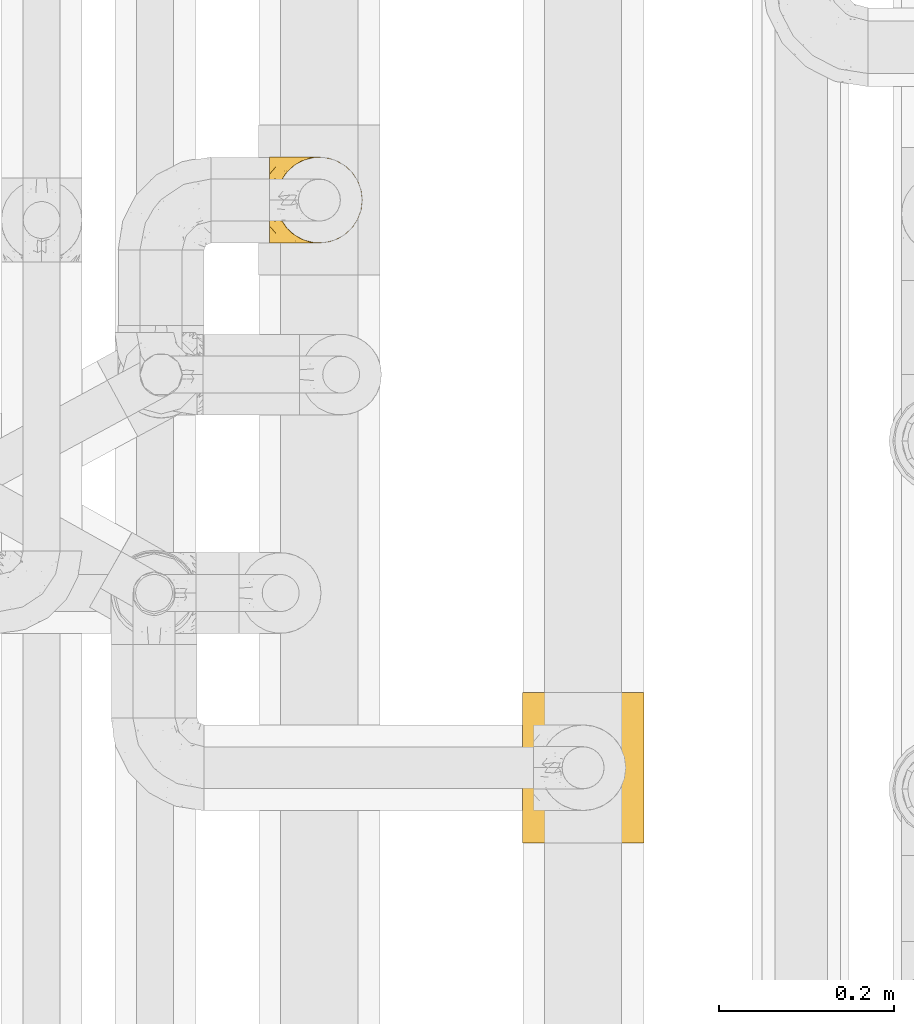
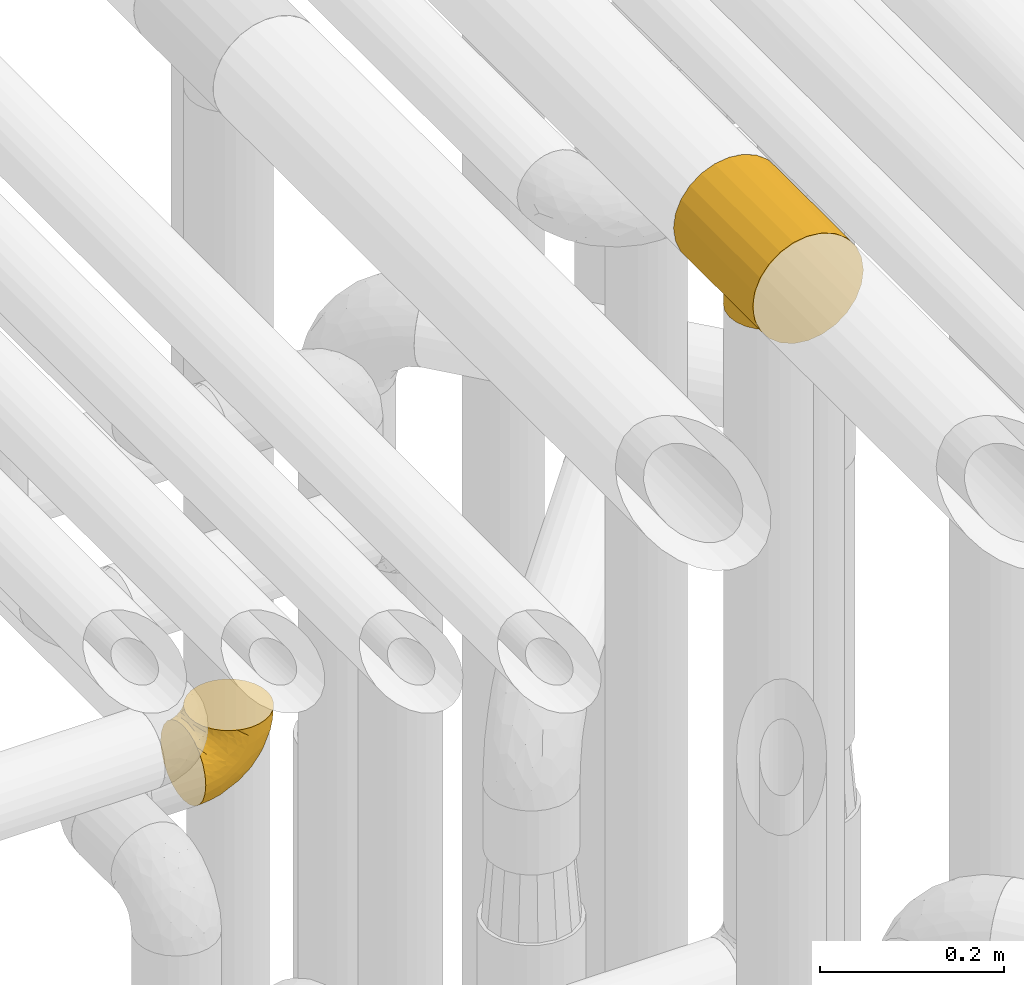
# One storey, part 210 of 827: 2 coverings.
"""IFC2X3 building model written with IfcOpenShell, lengths in millimetres."""

import ifcopenshell
import ifcopenshell.guid

model = None  # the IFC model being written
_history = None  # IfcOwnerHistory: only IFC2X3 demands one
_inside = {}  # id of a spatial element -> (the spatial element, [elements in it])
_under = {}  # id of a project, library or spatial element -> (it, [spatial elements below it])
_declared = {}  # id of a project -> (the project, [libraries it declares])
_typed = {}  # id of a type object -> (the type object, [elements of that type])
_made_of = {}  # id of a material, layer set ... -> (it, [elements and type objects made of it])


def new_model(schema):
    """Start an empty IFC model of exactly this schema.

    Asked for "IFC4X3", IfcOpenShell would pick the latest addendum, in which some entities
    have other attributes; the version numbers below select the first issue.
    IFC2X3 requires an IfcOwnerHistory on every rooted entity: one is made here for all.
    """
    global model, _history
    if schema == "IFC4X3":
        model = ifcopenshell.file(schema_version=(4, 3, 0, 0))
    else:
        model = ifcopenshell.file(schema=schema)
    _inside.clear()
    _under.clear()
    _declared.clear()
    _typed.clear()
    _made_of.clear()
    _history = None
    if model.schema == "IFC2X3":
        org = make("IfcOrganization", Name="unknown")
        user = make(
            "IfcPersonAndOrganization",
            ThePerson=make("IfcPerson", FamilyName="unknown"),
            TheOrganization=org,
        )
        app = make(
            "IfcApplication",
            ApplicationDeveloper=org,
            Version="unknown",
            ApplicationFullName="unknown",
            ApplicationIdentifier="unknown",
        )
        _history = make(
            "IfcOwnerHistory",
            OwningUser=user,
            OwningApplication=app,
            ChangeAction="ADDED",
            CreationDate=0,
        )
    return model


def make(cls, **values):
    """One entity of the class cls with the attributes given. An attribute that is None is left unset."""
    return model.create_entity(
        cls, **{name: value for name, value in values.items() if value is not None}
    )


def entity(cls, *values):
    """Any entity or typed value of the class cls, its attributes in the order of the schema. None: left unset."""
    e = model.create_entity(cls)
    for i, value in enumerate(values):
        if value is not None:
            e[i] = value
    return e


def rooted(cls, **values):
    """An entity with a GlobalId (a new one), such as an element, a storey or a relation."""
    return make(cls, GlobalId=ifcopenshell.guid.new(), OwnerHistory=_history, **values)


def si_unit(unit_type, name, prefix=None):
    """IfcSIUnit, for example si_unit("LENGTHUNIT", "METRE", prefix="MILLI")."""
    return make("IfcSIUnit", UnitType=unit_type, Prefix=prefix, Name=name)


def converted_unit(unit_type, name, factor, base, dimensions=None, offset=None):
    """IfcConversionBasedUnit, such as the inch: factor (a typed value) times the base unit."""
    return make(
        "IfcConversionBasedUnit"
        if offset is None
        else "IfcConversionBasedUnitWithOffset",
        ConversionOffset=offset,
        Dimensions=None
        if dimensions is None
        else entity("IfcDimensionalExponents", *dimensions),
        UnitType=unit_type,
        Name=name,
        ConversionFactor=make(
            "IfcMeasureWithUnit", ValueComponent=factor, UnitComponent=base
        ),
    )


def derived_unit(unit_type, elements):
    """IfcDerivedUnit: a product of units, each with its exponent."""
    return make(
        "IfcDerivedUnit",
        Elements=[
            make("IfcDerivedUnitElement", Unit=unit, Exponent=power)
            for unit, power in elements
        ],
        UnitType=unit_type,
    )


def assignment(units):
    """IfcUnitAssignment: the units of a project."""
    return None if units is None else make("IfcUnitAssignment", Units=units)


def point(xyz):
    """IfcCartesianPoint."""
    return None if xyz is None else make("IfcCartesianPoint", Coordinates=xyz)


def direction(xyz):
    """IfcDirection."""
    return None if xyz is None else make("IfcDirection", DirectionRatios=xyz)


def frame(location, z_axis=None, x_axis=None):
    """IfcAxis2Placement3D, a coordinate frame: its origin and axes. An axis left out is left unset."""
    return make(
        "IfcAxis2Placement3D",
        Location=point(location),
        Axis=direction(z_axis),
        RefDirection=direction(x_axis),
    )


def origin():
    """The frame at (0, 0, 0) with its axes left unset."""
    return frame((0.0, 0.0, 0.0))


def place(relative_to, where):
    """IfcLocalPlacement: puts the frame where relative to a parent placement (None: the world)."""
    return make(
        "IfcLocalPlacement", PlacementRelTo=relative_to, RelativePlacement=where
    )


def context(
    kind, dimensions, precision=None, world=None, true_north=None, identifier=None
):
    """IfcGeometricRepresentationContext, for example the 3D "Model" context."""
    return make(
        "IfcGeometricRepresentationContext",
        ContextIdentifier=identifier,
        ContextType=kind,
        CoordinateSpaceDimension=dimensions,
        Precision=precision,
        WorldCoordinateSystem=world,
        TrueNorth=true_north,
    )


def subcontext(parent, identifier, kind, view, scale=None):
    """IfcGeometricRepresentationSubContext, for example "Body" below "Model"."""
    return make(
        "IfcGeometricRepresentationSubContext",
        ContextIdentifier=identifier,
        ContextType=kind,
        ParentContext=parent,
        TargetScale=scale,
        TargetView=view,
    )


def project(units=None, contexts=None):
    """IfcProject with its units and contexts."""
    return rooted(
        "IfcProject",
        Name="project",
        RepresentationContexts=contexts,
        UnitsInContext=assignment(units),
    )


def spatial(cls, under=None, at=None, **own):
    """A site, building, storey or space (cls), placed at a placement, below another one or the project."""
    s = rooted(cls, ObjectPlacement=at, **own)
    if under is not None:
        _under.setdefault(under.id(), (under, []))[1].append(s)
    return s


def faces_of(points, faces, orient=None, outer=None):
    """IfcFace entities. A face is a list of loops; a loop is a list of indices into points, from 0.

    orient and outer hold one flag for each loop. By default every Orientation is true, the
    first loop of a face is its IfcFaceOuterBound and the others are IfcFaceBound.
    """
    made = []
    for i, loops in enumerate(faces):
        bounds = []
        for j, loop in enumerate(loops):
            is_outer = j == 0 if outer is None else outer[i][j]
            bounds.append(
                make(
                    "IfcFaceOuterBound" if is_outer else "IfcFaceBound",
                    Bound=make("IfcPolyLoop", Polygon=[points[k] for k in loop]),
                    Orientation=True if orient is None else orient[i][j],
                )
            )
        made.append(make("IfcFace", Bounds=bounds))
    return made


def faceted_brep(points, faces, orient=None, outer=None, voids=None):
    """IfcFacetedBrep: a solid bounded by flat faces; with voids (closed shells), ...WithVoids."""
    shared = [point(p) for p in points]
    hull = make("IfcClosedShell", CfsFaces=faces_of(shared, faces, orient, outer))
    if voids is None:
        return make("IfcFacetedBrep", Outer=hull)
    return make(
        "IfcFacetedBrepWithVoids",
        Outer=hull,
        Voids=[
            make(cls, CfsFaces=faces_of(shared, fs, o, b)) for cls, fs, o, b in voids
        ],
    )


def shape(context_of_items, identifier, shape_type, items):
    """IfcShapeRepresentation: the items that make up one representation, for example the "Body"."""
    return make(
        "IfcShapeRepresentation",
        ContextOfItems=context_of_items,
        RepresentationIdentifier=identifier,
        RepresentationType=shape_type,
        Items=items,
    )


def made_of(thing, what):
    """Note that an element or type object is made of a material, layer set ...; save() writes the relation."""
    if what is not None:
        _made_of.setdefault(what.id(), (what, []))[1].append(thing)
    return thing


def element(
    cls,
    number,
    at=None,
    inside=None,
    cuts=None,
    type_object=None,
    material=None,
    context=None,
    identifier="Body",
    shape_type=None,
    held_by="IfcProductDefinitionShape",
    body=None,
    shapes=None,
    **own,
):
    """One element of the class cls, such as IfcWall. Its Tag is "e" and its number.

    at: its placement. inside: the storey or other place that contains it. cuts: it is an
    opening in that element (IfcRelVoidsElement). A single representation is given by context,
    identifier, shape_type and body (its items); several are given by shapes. held_by: the class
    of the entity that holds the representations. save() writes the other relations.
    """
    e = rooted(cls, Tag="e%d" % number, ObjectPlacement=at, **own)
    if body is not None:
        shapes = [shape(context, identifier, shape_type, body)]
    if shapes is not None:
        e.Representation = make(held_by, Representations=shapes)
    if inside is not None:
        _inside.setdefault(inside.id(), (inside, []))[1].append(e)
    if cuts is not None:
        rooted(
            "IfcRelVoidsElement", RelatingBuildingElement=cuts, RelatedOpeningElement=e
        )
    if type_object is not None:
        _typed.setdefault(type_object.id(), (type_object, []))[1].append(e)
    return made_of(e, material)


def aggregate(whole, parts):
    """IfcRelAggregates: a whole, such as a stair, and the parts it consists of."""
    return rooted("IfcRelAggregates", RelatingObject=whole, RelatedObjects=parts)


def save(model, path):
    """Write the relations noted so far, then the file.

    IfcRelAggregates (storeys below a building ...), IfcRelContainedInSpatialStructure (elements
    in a storey), IfcRelDefinesByType, IfcRelAssociatesMaterial and IfcRelDeclares: one each for
    every whole, place, type object, material and project.
    """
    for whole, parts in _under.values():
        aggregate(whole, parts)
    for where, things in _inside.values():
        rooted(
            "IfcRelContainedInSpatialStructure",
            RelatedElements=things,
            RelatingStructure=where,
        )
    for kind, things in _typed.values():
        rooted("IfcRelDefinesByType", RelatedObjects=things, RelatingType=kind)
    for what, things in _made_of.values():
        rooted("IfcRelAssociatesMaterial", RelatedObjects=things, RelatingMaterial=what)
    for by, libraries in _declared.values():
        rooted("IfcRelDeclares", RelatingContext=by, RelatedDefinitions=libraries)
    model.write(path)


model = new_model("IFC2X3")

# Units and contexts
model_context = context("Model", 3, precision=0.01, world=origin(), true_north=direction((6.12303176911189e-17, 1.0)))
body_context = subcontext(model_context, "Body", "Model", "MODEL_VIEW")
ifc_project = project(units=[si_unit("LENGTHUNIT", "METRE", prefix="MILLI"), si_unit("AREAUNIT", "SQUARE_METRE"), si_unit("VOLUMEUNIT", "CUBIC_METRE"), converted_unit("PLANEANGLEUNIT", "DEGREE", entity("IfcRatioMeasure", 0.0174532925199433), si_unit("PLANEANGLEUNIT", "RADIAN"), dimensions=[0, 0, 0, 0, 0, 0, 0]), si_unit("MASSUNIT", "GRAM", prefix="KILO"), derived_unit("MASSDENSITYUNIT", [(si_unit("MASSUNIT", "GRAM", prefix="KILO"), 1), (si_unit("LENGTHUNIT", "METRE"), -3)]), derived_unit("MOMENTOFINERTIAUNIT", [(si_unit("LENGTHUNIT", "METRE"), 4)]), si_unit("TIMEUNIT", "SECOND"), si_unit("FREQUENCYUNIT", "HERTZ"), si_unit("THERMODYNAMICTEMPERATUREUNIT", "DEGREE_CELSIUS"), derived_unit("THERMALTRANSMITTANCEUNIT", [(si_unit("MASSUNIT", "GRAM", prefix="KILO"), 1), (si_unit("THERMODYNAMICTEMPERATUREUNIT", "KELVIN"), -1), (si_unit("TIMEUNIT", "SECOND"), -3)]), derived_unit("VOLUMETRICFLOWRATEUNIT", [(si_unit("LENGTHUNIT", "METRE"), 3), (si_unit("TIMEUNIT", "SECOND"), -1)]), derived_unit("MASSFLOWRATEUNIT", [(si_unit("MASSUNIT", "GRAM", prefix="KILO"), 1), (si_unit("TIMEUNIT", "SECOND"), -1)]), derived_unit("ROTATIONALFREQUENCYUNIT", [(si_unit("TIMEUNIT", "SECOND"), -1)]), si_unit("ELECTRICCURRENTUNIT", "AMPERE"), si_unit("ELECTRICVOLTAGEUNIT", "VOLT"), si_unit("POWERUNIT", "WATT"), si_unit("FORCEUNIT", "NEWTON", prefix="KILO"), si_unit("ILLUMINANCEUNIT", "LUX"), si_unit("LUMINOUSFLUXUNIT", "LUMEN"), si_unit("LUMINOUSINTENSITYUNIT", "CANDELA"), derived_unit("USERDEFINED", [(si_unit("MASSUNIT", "GRAM", prefix="KILO"), -1), (si_unit("LENGTHUNIT", "METRE"), -2), (si_unit("TIMEUNIT", "SECOND"), 3), (si_unit("LUMINOUSFLUXUNIT", "LUMEN"), 1)]), derived_unit("LINEARVELOCITYUNIT", [(si_unit("LENGTHUNIT", "METRE"), 1), (si_unit("TIMEUNIT", "SECOND"), -1)]), si_unit("PRESSUREUNIT", "PASCAL"), derived_unit("USERDEFINED", [(si_unit("LENGTHUNIT", "METRE"), -2), (si_unit("MASSUNIT", "GRAM", prefix="KILO"), 1), (si_unit("TIMEUNIT", "SECOND"), -2)]), derived_unit("LINEARFORCEUNIT", [(si_unit("MASSUNIT", "GRAM", prefix="KILO"), 1), (si_unit("LENGTHUNIT", "METRE"), 1), (si_unit("TIMEUNIT", "SECOND"), -2), (si_unit("LENGTHUNIT", "METRE"), -1)]), derived_unit("PLANARFORCEUNIT", [(si_unit("MASSUNIT", "GRAM", prefix="KILO"), 1), (si_unit("LENGTHUNIT", "METRE"), 1), (si_unit("TIMEUNIT", "SECOND"), -2), (si_unit("LENGTHUNIT", "METRE"), -2)])], contexts=[model_context])

# Site, building, storey
site_placement = place(None, origin())
site = spatial("IfcSite", under=ifc_project, at=site_placement, CompositionType="ELEMENT")
building_placement = place(site_placement, origin())
building = spatial("IfcBuilding", under=site, at=building_placement, CompositionType="ELEMENT")
storey_placement = place(building_placement, frame((0.0, 0.0, 28200.0)))
storey = spatial("IfcBuildingStorey", under=building, at=storey_placement, Name="08", CompositionType="ELEMENT", Elevation=28200.0)

# Coverings
covering_1_placement = place(storey_placement, frame((35859.47, 11955.34, 2549.25)))
element("IfcCovering", 1, at=covering_1_placement, inside=storey, Name=":ADSK_", ObjectType=":ADSK_", PredefinedType="INSULATION", context=body_context, shape_type="Brep", body=[
    faceted_brep([(58.6, 1.6, 107.75), (69.54, 2.83, 107.75), (79.93, 6.47, 107.75), (89.25, 12.32, 107.75), (97.03, 20.11, 107.75), (102.88, 29.43, 107.75), (106.51, 39.81, 107.75), (107.75, 50.75, 107.75), (106.51, 61.69, 107.75), (102.87, 72.08, 107.75), (97.02, 81.4, 107.75), (89.23, 89.18, 107.75), (79.91, 95.03, 107.75), (69.53, 98.66, 107.75), (58.6, 99.9, 107.75), (52.89, 99.25, 107.75), (47.65, 98.66, 107.75), (42.46, 96.84, 107.75), (37.26, 95.02, 107.75), (27.94, 89.17, 107.75), (20.16, 81.38, 107.75), (14.31, 72.06, 107.75), (10.68, 61.68, 107.75), (9.45, 50.75, 107.75), (10.68, 39.8, 107.75), (14.32, 29.41, 107.75), (20.17, 20.09, 107.75), (27.96, 12.31, 107.75), (37.28, 6.46, 107.75), (42.47, 4.64, 107.75), (47.66, 2.83, 107.75), (52.89, 2.24, 107.75), (55.75, 1.92, 107.75), (1.6, 63.47, 98.22), (1.6, 75.32, 93.31), (1.6, 80.41, 89.4), (1.6, 85.5, 85.5), (1.6, 89.4, 80.41), (1.6, 93.31, 75.32), (1.6, 95.77, 69.39), (1.6, 98.22, 63.47), (1.6, 99.14, 56.48), (1.6, 99.52, 53.61), (1.6, 99.9, 50.75), (1.6, 98.22, 38.02), (1.6, 93.31, 26.17), (1.6, 85.5, 15.99), (1.6, 75.32, 8.18), (1.6, 63.47, 3.27), (1.6, 50.75, 1.6), (1.6, 38.02, 3.27), (1.6, 26.17, 8.18), (1.6, 15.99, 15.99), (1.6, 8.18, 26.17), (1.6, 3.27, 38.02), (1.6, 1.6, 50.75), (1.6, 2.35, 56.48), (1.6, 3.27, 63.47), (1.6, 5.73, 69.39), (1.6, 8.18, 75.32), (1.6, 12.09, 80.41), (1.6, 15.99, 85.5), (1.6, 21.08, 89.4), (1.6, 26.17, 93.31), (1.6, 38.02, 98.22), (1.6, 50.75, 99.9), (69.96, 42.18, 27.53), (59.59, 28.42, 25.32), (51.96, 37.78, 16.29), (34.4, 50.75, 6.79), (23.37, 42.85, 4.51), (13.68, 50.75, 3.51), (41.52, 24.75, 17.47), (26.26, 33.81, 7.6), (20.18, 22.57, 12.27), (72.33, 7.18, 70.89), (65.88, 2.73, 87.17), (57.55, 3.09, 67.3), (23.76, 6.92, 31.65), (46.5, 11.58, 33.58), (46.57, 5.17, 47.23), (21.17, 2.71, 43.26), (23.41, 1.6, 55.08), (17.92, 1.6, 53.99), (12.43, 1.6, 52.9), (9.72, 1.6, 52.36), (7.01, 1.6, 51.82), (26.77, 14.18, 21.5), (76.59, 5.88, 89.94), (95.55, 41.06, 60.45), (102.57, 36.25, 83.0), (92.89, 28.62, 64.79), (54.26, 1.6, 85.93), (51.17, 1.6, 81.31), (48.08, 1.6, 76.69), (44.99, 1.6, 72.06), (41.9, 1.6, 67.44), (85.16, 10.85, 88.74), (85.97, 38.35, 45.98), (59.58, 9.6, 47.13), (99.5, 26.24, 89.4), (105.83, 50.75, 95.66), (53.59, 19.31, 28.5), (67.0, 16.41, 42.81), (71.56, 24.56, 38.28), (87.47, 50.75, 45.35), (75.73, 50.75, 33.61), (92.24, 18.47, 82.57), (58.06, 1.6, 105.04), (57.52, 1.6, 102.33), (56.44, 1.6, 96.91), (55.35, 1.6, 91.42), (81.33, 14.36, 65.92), (80.35, 20.64, 53.11), (39.44, 2.32, 54.37), (102.55, 50.75, 74.94), (37.28, 1.6, 64.35), (32.65, 1.6, 61.26), (28.03, 1.6, 58.17), (63.99, 50.75, 21.87), (74.55, 33.88, 34.79), (83.62, 29.24, 48.48), (95.01, 50.75, 60.15), (49.19, 50.75, 14.33), (46.96, 2.8, 99.07), (8.77, 2.48, 60.55), (18.28, 2.7, 64.18), (11.68, 3.2, 64.36), (11.79, 32.98, 103.17), (15.69, 24.67, 101.69), (42.49, 2.95, 87.75), (47.41, 2.19, 89.38), (7.94, 17.92, 88.34), (9.27, 12.02, 82.14), (7.98, 25.73, 94.51), (13.4, 16.63, 89.64), (13.04, 25.6, 98.41), (7.36, 36.72, 99.71), (23.46, 10.66, 89.37), (30.46, 6.87, 88.21), (26.54, 11.12, 95.2), (6.76, 10.31, 79.14), (26.46, 12.84, 101.22), (20.77, 17.38, 99.41), (20.68, 9.74, 84.72), (40.26, 4.63, 97.47), (7.15, 50.75, 102.19), (9.28, 42.52, 104.02), (38.78, 3.12, 82.66), (18.27, 17.58, 95.42), (31.78, 3.97, 78.67), (12.75, 5.94, 72.69), (22.96, 2.73, 66.46), (17.55, 6.23, 75.3), (27.63, 3.45, 72.74), (15.23, 10.84, 82.93), (33.25, 7.98, 99.27), (32.43, 7.33, 93.51), (27.9, 2.39, 67.35), (7.97, 75.76, 94.51), (15.22, 90.65, 82.94), (7.93, 83.57, 88.33), (13.38, 84.85, 89.64), (13.12, 71.05, 103.62), (42.49, 98.54, 87.74), (47.4, 99.3, 89.38), (51.17, 99.9, 81.31), (40.24, 96.86, 97.47), (20.76, 84.1, 99.41), (12.43, 99.9, 52.9), (7.01, 99.9, 51.82), (4.31, 99.9, 51.28), (26.44, 88.63, 101.21), (26.52, 90.36, 95.19), (11.68, 98.29, 64.36), (12.75, 95.55, 72.69), (9.27, 89.47, 82.13), (17.55, 95.26, 75.3), (6.76, 91.18, 79.14), (33.21, 93.49, 99.28), (32.41, 94.15, 93.51), (8.77, 99.01, 60.55), (22.96, 98.76, 66.46), (18.48, 98.85, 63.96), (56.44, 99.9, 96.91), (46.95, 98.69, 99.06), (7.36, 64.78, 99.7), (17.92, 99.9, 53.99), (23.41, 99.9, 55.08), (9.85, 62.91, 103.3), (57.52, 99.9, 102.33), (56.98, 99.9, 99.62), (48.08, 99.9, 76.69), (38.78, 98.37, 82.66), (18.25, 83.9, 95.42), (44.99, 99.9, 72.06), (31.74, 97.51, 78.68), (30.45, 94.62, 88.2), (27.63, 98.04, 72.75), (20.65, 91.73, 84.74), (55.35, 99.9, 91.42), (54.26, 99.9, 85.93), (13.03, 75.87, 98.41), (23.44, 90.83, 89.37), (27.9, 99.1, 67.35), (32.65, 99.9, 61.26), (28.03, 99.9, 58.17), (37.28, 99.9, 64.35), (41.9, 99.9, 67.44), (39.74, 99.09, 54.08), (23.37, 58.64, 4.51), (26.77, 87.31, 21.5), (46.18, 89.93, 33.43), (53.54, 82.22, 28.5), (41.53, 76.74, 17.47), (59.61, 73.12, 25.36), (76.79, 95.54, 90.18), (66.11, 98.7, 86.97), (21.17, 98.79, 43.26), (51.96, 63.71, 16.29), (26.26, 67.68, 7.6), (20.18, 78.92, 12.27), (23.76, 94.57, 31.65), (92.88, 72.88, 64.79), (102.57, 65.25, 83.0), (95.54, 60.44, 60.44), (71.63, 76.94, 38.35), (74.55, 67.61, 34.8), (72.51, 94.38, 71.54), (69.96, 59.31, 27.53), (92.23, 83.03, 82.57), (85.15, 90.66, 88.74), (80.45, 80.8, 53.19), (83.65, 72.22, 48.49), (57.57, 98.39, 67.28), (63.68, 92.31, 52.32), (85.95, 63.11, 45.94), (99.49, 75.27, 89.4), (81.23, 87.15, 65.75), (47.07, 96.03, 46.73), (66.99, 85.1, 42.82)], [[[0, 1, 2, 3, 4, 5, 6, 7, 8, 9, 10, 11, 12, 13, 14, 15, 16, 17, 18, 19, 20, 21, 22, 23, 24, 25, 26, 27, 28, 29, 30, 31, 32]], [[33, 34, 35, 36, 37, 38, 39, 40, 41, 42, 43, 44, 45, 46, 47, 48, 49, 50, 51, 52, 53, 54, 55, 56, 57, 58, 59, 60, 61, 62, 63, 64, 65]], [[66, 67, 68]], [[69, 70, 71]], [[68, 72, 73]], [[73, 72, 74]], [[75, 76, 77]], [[78, 79, 80]], [[51, 50, 73]], [[81, 82, 83, 84, 85, 86, 55]], [[52, 87, 53]], [[74, 52, 51]], [[2, 1, 88]], [[89, 90, 91]], [[77, 92, 93, 94, 95, 96]], [[55, 54, 81]], [[78, 53, 87]], [[5, 90, 6]], [[88, 76, 75]], [[97, 3, 2]], [[89, 91, 98]], [[99, 80, 79]], [[90, 5, 100]], [[74, 87, 52]], [[100, 5, 4]], [[90, 101, 6]], [[79, 102, 103]], [[102, 67, 104]], [[105, 98, 106]], [[107, 4, 3]], [[76, 0, 108, 109, 110, 111, 92]], [[107, 112, 113]], [[114, 77, 96]], [[89, 115, 90]], [[114, 96, 116, 117, 118, 82]], [[75, 97, 88]], [[119, 66, 68]], [[50, 71, 70]], [[100, 91, 90]], [[99, 77, 80]], [[102, 104, 103]], [[97, 107, 3]], [[80, 81, 78]], [[107, 97, 112]], [[68, 73, 70]], [[66, 98, 120]], [[78, 81, 54]], [[114, 81, 80]], [[53, 78, 54]], [[78, 87, 79]], [[102, 87, 72]], [[79, 103, 99]], [[4, 107, 100]], [[91, 100, 107]], [[88, 97, 2]], [[112, 97, 75]], [[99, 112, 75]], [[103, 104, 113]], [[91, 121, 98]], [[89, 105, 122, 115]], [[101, 90, 115]], [[101, 7, 6]], [[88, 1, 76]], [[0, 76, 1]], [[92, 77, 76]], [[73, 74, 51]], [[87, 74, 72]], [[81, 114, 82]], [[77, 114, 80]], [[87, 102, 79]], [[67, 102, 72]], [[68, 67, 72]], [[67, 120, 104]], [[120, 121, 104]], [[104, 121, 113]], [[121, 120, 98]], [[91, 107, 113]], [[91, 113, 121]], [[103, 113, 112]], [[106, 98, 66]], [[105, 89, 98]], [[106, 66, 119]], [[67, 66, 120]], [[68, 69, 123, 119]], [[50, 49, 71]], [[50, 70, 73]], [[112, 99, 103]], [[77, 99, 75]], [[69, 68, 70]], [[29, 124, 110]], [[84, 83, 125]], [[126, 82, 118]], [[59, 58, 127]], [[25, 128, 129]], [[130, 93, 131]], [[132, 62, 133]], [[134, 135, 136]], [[137, 65, 64]], [[64, 134, 137]], [[138, 139, 140]], [[111, 110, 124, 92]], [[134, 136, 137]], [[134, 64, 63]], [[141, 61, 60]], [[125, 58, 57]], [[142, 143, 140]], [[142, 26, 143]], [[127, 83, 82]], [[28, 124, 29]], [[108, 0, 32, 31, 30, 110, 109]], [[30, 29, 110]], [[135, 144, 138]], [[28, 145, 124]], [[57, 56, 55, 86, 85, 84]], [[146, 147, 23]], [[24, 23, 147]], [[25, 143, 26]], [[95, 94, 148]], [[24, 128, 25]], [[149, 138, 143]], [[124, 145, 131]], [[127, 58, 125]], [[150, 148, 139]], [[127, 126, 151]], [[151, 59, 127]], [[152, 151, 126]], [[153, 154, 155]], [[153, 133, 141]], [[145, 28, 27]], [[142, 156, 27]], [[157, 148, 130]], [[61, 133, 62]], [[134, 132, 135]], [[147, 128, 24]], [[65, 137, 146]], [[146, 137, 147]], [[128, 137, 136]], [[137, 128, 147]], [[128, 136, 129]], [[149, 129, 136]], [[25, 129, 143]], [[158, 152, 117]], [[152, 118, 117]], [[153, 151, 152]], [[158, 116, 154]], [[144, 150, 138]], [[153, 152, 158]], [[133, 153, 155]], [[133, 155, 132]], [[60, 151, 141]], [[135, 132, 155]], [[134, 63, 132]], [[144, 135, 155]], [[135, 138, 149]], [[155, 154, 144]], [[150, 154, 96]], [[154, 150, 144]], [[148, 94, 130]], [[82, 126, 127]], [[118, 152, 126]], [[150, 96, 95]], [[139, 148, 157]], [[150, 95, 148]], [[93, 92, 131]], [[130, 145, 156]], [[130, 94, 93]], [[84, 125, 57]], [[127, 125, 83]], [[140, 139, 157]], [[150, 139, 138]], [[140, 157, 142]], [[138, 140, 143]], [[156, 142, 157]], [[27, 26, 142]], [[130, 156, 157]], [[145, 27, 156]], [[132, 63, 62]], [[124, 131, 92]], [[130, 131, 145]], [[129, 149, 143]], [[135, 149, 136]], [[141, 133, 61]], [[60, 59, 151]], [[141, 151, 153]], [[116, 96, 154]], [[153, 158, 154]], [[158, 117, 116]], [[34, 33, 159]], [[160, 161, 162]], [[22, 21, 163]], [[164, 165, 166]], [[19, 18, 167]], [[168, 21, 20]], [[42, 41, 40, 169, 170, 171, 43]], [[172, 173, 168]], [[174, 38, 175]], [[176, 177, 178]], [[179, 164, 180]], [[40, 181, 169]], [[182, 183, 175]], [[17, 184, 185]], [[65, 146, 186]], [[187, 174, 188]], [[23, 22, 189]], [[174, 39, 38]], [[15, 14, 190, 191, 184, 16]], [[181, 40, 39]], [[192, 193, 164]], [[194, 163, 168]], [[33, 186, 159]], [[180, 173, 172]], [[195, 196, 193]], [[18, 185, 167]], [[173, 180, 197]], [[198, 199, 196]], [[200, 201, 185, 184]], [[184, 17, 16]], [[18, 17, 185]], [[202, 159, 186]], [[194, 168, 203]], [[189, 163, 202]], [[204, 205, 182]], [[187, 181, 174]], [[160, 177, 176]], [[206, 183, 182]], [[206, 182, 205]], [[201, 165, 185]], [[165, 164, 167]], [[172, 179, 180]], [[202, 194, 162]], [[176, 161, 160]], [[65, 186, 33]], [[163, 189, 22]], [[175, 177, 182]], [[174, 183, 188]], [[177, 198, 204]], [[199, 160, 162]], [[198, 207, 204]], [[175, 38, 37]], [[198, 177, 160]], [[178, 177, 175]], [[176, 35, 161]], [[34, 159, 161]], [[162, 161, 159]], [[202, 162, 159]], [[199, 162, 203]], [[196, 199, 203]], [[198, 160, 199]], [[193, 197, 180]], [[208, 198, 196]], [[188, 183, 206]], [[175, 183, 174]], [[193, 192, 195]], [[195, 208, 196]], [[197, 196, 203]], [[180, 164, 193]], [[168, 163, 21]], [[166, 165, 201]], [[166, 192, 164]], [[189, 202, 186]], [[186, 146, 189]], [[23, 189, 146]], [[174, 181, 39]], [[169, 181, 187]], [[196, 197, 193]], [[173, 203, 168]], [[203, 173, 197]], [[172, 168, 20]], [[20, 19, 172]], [[179, 172, 19]], [[19, 167, 179]], [[164, 179, 167]], [[35, 176, 36]], [[35, 34, 161]], [[185, 165, 167]], [[162, 194, 203]], [[163, 194, 202]], [[176, 178, 36]], [[37, 36, 178]], [[175, 37, 178]], [[177, 204, 182]], [[207, 198, 208]], [[207, 205, 204]], [[209, 188, 206, 205, 207, 208]], [[48, 210, 71]], [[211, 212, 213]], [[214, 213, 215]], [[216, 217, 13]], [[218, 43, 171, 170, 169, 187, 188]], [[219, 220, 214]], [[47, 46, 221]], [[210, 48, 220]], [[211, 222, 212]], [[222, 45, 44]], [[221, 220, 47]], [[47, 220, 48]], [[221, 211, 214]], [[223, 224, 225]], [[211, 46, 45]], [[226, 227, 215]], [[43, 218, 44]], [[217, 216, 228]], [[219, 215, 229]], [[14, 13, 217]], [[224, 9, 8]], [[10, 230, 11]], [[11, 231, 12]], [[232, 223, 233]], [[234, 208, 195, 192, 166, 201]], [[235, 234, 228]], [[222, 44, 218]], [[106, 229, 236]], [[224, 237, 9]], [[231, 238, 228]], [[9, 237, 10]], [[115, 224, 101]], [[239, 234, 235]], [[231, 11, 230]], [[223, 230, 237]], [[224, 8, 101]], [[223, 236, 233]], [[225, 115, 122, 105]], [[216, 12, 231]], [[209, 234, 239]], [[210, 219, 69]], [[219, 214, 215]], [[229, 119, 219]], [[209, 218, 188]], [[239, 212, 222]], [[239, 222, 218]], [[45, 222, 211]], [[235, 212, 239]], [[213, 212, 240]], [[223, 237, 224]], [[230, 10, 237]], [[238, 231, 230]], [[216, 231, 228]], [[232, 230, 223]], [[235, 238, 240]], [[115, 225, 224]], [[233, 236, 227]], [[8, 7, 101]], [[234, 209, 208]], [[218, 209, 239]], [[217, 228, 234]], [[13, 12, 216]], [[234, 201, 217]], [[217, 201, 200, 184, 191, 190, 14]], [[211, 221, 46]], [[220, 221, 214]], [[71, 210, 69]], [[71, 49, 48]], [[219, 210, 220]], [[226, 215, 213]], [[211, 213, 214]], [[226, 213, 240]], [[215, 227, 229]], [[232, 240, 238]], [[233, 227, 226]], [[232, 233, 226]], [[236, 223, 225]], [[240, 232, 226]], [[232, 238, 230]], [[225, 105, 236]], [[236, 105, 106]], [[236, 229, 227]], [[123, 69, 219, 119]], [[106, 119, 229]], [[238, 235, 228]], [[212, 235, 240]]]),
])
covering_2_placement = place(storey_placement, frame((36148.99, 11270.08, 3477.0)))
element("IfcCovering", 2, at=covering_2_placement, inside=storey, Name=":ADSK_", ObjectType=":ADSK_", PredefinedType="INSULATION", context=body_context, shape_type="Brep", body=[
    faceted_brep([(3.96, 172.0, 90.97), (10.9, 172.0, 107.72), (21.94, 172.0, 122.11), (36.32, 172.0, 133.15), (53.07, 172.0, 140.08), (71.05, 172.0, 142.45), (89.02, 172.0, 140.08), (105.77, 172.0, 133.15), (120.15, 172.0, 122.11), (131.19, 172.0, 107.72), (138.13, 172.0, 90.97), (140.5, 172.0, 73.0), (138.13, 172.0, 55.03), (131.19, 172.0, 38.27), (120.15, 172.0, 23.89), (105.77, 172.0, 12.85), (97.4, 172.0, 9.39), (89.02, 172.0, 5.92), (80.03, 172.0, 4.73), (71.05, 172.0, 3.55), (62.06, 172.0, 4.73), (53.07, 172.0, 5.92), (44.7, 172.0, 9.39), (36.32, 172.0, 12.85), (21.94, 172.0, 23.89), (10.9, 172.0, 38.27), (3.96, 172.0, 55.03), (1.6, 172.0, 73.0), (120.15, 0.0, 122.11), (105.77, 0.0, 133.15), (89.02, 0.0, 140.08), (71.05, 0.0, 142.45), (53.07, 0.0, 140.08), (36.32, 0.0, 133.15), (21.94, 0.0, 122.11), (10.9, 0.0, 107.73), (3.96, 0.0, 90.97), (1.6, 0.0, 73.0), (3.96, 0.0, 55.03), (10.9, 0.0, 38.28), (21.94, 0.0, 23.89), (36.32, 0.0, 12.85), (44.7, 0.0, 9.39), (53.07, 0.0, 5.92), (62.06, 0.0, 4.73), (71.05, 0.0, 3.55), (80.03, 0.0, 4.73), (89.02, 0.0, 5.92), (97.4, 0.0, 9.39), (105.77, 0.0, 12.85), (120.15, 0.0, 23.89), (131.19, 0.0, 38.28), (138.13, 0.0, 55.03), (140.5, 0.0, 73.0), (138.13, 0.0, 90.97), (131.19, 0.0, 107.73), (109.48, 55.36, 15.15), (115.18, 64.37, 19.38), (92.88, 130.03, 7.07), (118.88, 74.72, 22.65), (82.39, 38.18, 4.48), (120.2, 86.0, 23.93), (118.88, 97.28, 22.65), (82.39, 133.82, 4.48), (76.72, 134.49, 4.02), (71.05, 135.15, 3.55), (109.48, 116.64, 15.15), (115.18, 107.63, 19.38), (102.0, 47.82, 10.83), (92.88, 41.97, 7.07), (71.05, 36.85, 3.55), (76.72, 37.51, 4.02), (87.64, 40.07, 5.78), (102.0, 124.18, 10.83), (87.64, 131.93, 5.78), (59.7, 38.18, 4.48), (40.09, 47.82, 10.83), (49.21, 41.97, 7.07), (54.46, 40.07, 5.78), (65.38, 134.49, 4.02), (59.7, 133.82, 4.48), (40.09, 124.18, 10.83), (49.21, 130.03, 7.07), (32.61, 116.64, 15.15), (54.46, 131.93, 5.78), (32.61, 55.36, 15.15), (26.91, 64.37, 19.38), (23.21, 74.72, 22.65), (65.38, 37.51, 4.02), (21.9, 86.0, 23.93), (26.91, 107.63, 19.38), (23.21, 97.28, 22.65), (118.52, 73.28, 0.0), (113.61, 61.42, 0.0), (105.8, 51.25, 0.0), (95.62, 43.43, 0.0), (89.69, 40.98, 0.0), (83.77, 38.52, 0.0), (77.41, 37.69, 0.0), (71.05, 36.85, 0.0), (64.68, 37.69, 0.0), (58.32, 38.52, 0.0), (52.4, 40.98, 0.0), (46.47, 43.43, 0.0), (36.29, 51.25, 0.0), (28.48, 61.42, 0.0), (23.57, 73.28, 0.0), (21.9, 86.0, 0.0), (23.57, 98.72, 0.0), (28.48, 110.57, 0.0), (36.29, 120.75, 0.0), (46.47, 128.57, 0.0), (52.4, 131.02, 0.0), (58.32, 133.48, 0.0), (64.68, 134.31, 0.0), (71.05, 135.15, 0.0), (77.41, 134.31, 0.0), (83.77, 133.48, 0.0), (89.69, 131.02, 0.0), (95.62, 128.57, 0.0), (105.8, 120.75, 0.0), (113.61, 110.57, 0.0), (118.52, 98.72, 0.0), (120.2, 86.0, 0.0)], [[[0, 1, 2, 3, 4, 5, 6, 7, 8, 9, 10, 11, 12, 13, 14, 15, 16, 17, 18, 19, 20, 21, 22, 23, 24, 25, 26, 27]], [[28, 29, 30, 31, 32, 33, 34, 35, 36, 37, 38, 39, 40, 41, 42, 43, 44, 45, 46, 47, 48, 49, 50, 51, 52, 53, 54, 55]], [[29, 28, 8, 7]], [[5, 31, 30, 6]], [[7, 6, 30, 29]], [[9, 55, 54, 10]], [[10, 54, 53, 11]], [[8, 28, 55, 9]], [[52, 12, 11, 53]], [[51, 13, 12, 52]], [[50, 56, 57]], [[56, 50, 49]], [[58, 17, 16]], [[57, 59, 50]], [[60, 47, 46]], [[51, 50, 61]], [[50, 59, 61]], [[61, 62, 14]], [[18, 63, 64, 65]], [[66, 14, 67]], [[67, 14, 62]], [[68, 48, 69]], [[61, 14, 13]], [[61, 13, 51]], [[48, 68, 49]], [[69, 48, 47]], [[45, 70, 46]], [[65, 19, 18]], [[46, 70, 71, 60]], [[47, 60, 72, 69]], [[66, 73, 15]], [[73, 16, 15]], [[16, 73, 58]], [[66, 15, 14]], [[18, 17, 63]], [[17, 58, 74, 63]], [[68, 56, 49]], [[45, 44, 70]], [[65, 20, 19]], [[75, 44, 43]], [[41, 76, 42]], [[77, 42, 76]], [[43, 77, 78, 75]], [[20, 65, 79, 80]], [[81, 23, 22]], [[22, 21, 82]], [[23, 81, 83]], [[21, 80, 84, 82]], [[85, 76, 41]], [[86, 85, 40]], [[87, 86, 40]], [[44, 75, 88, 70]], [[39, 38, 26, 25]], [[89, 40, 39]], [[87, 40, 89]], [[85, 41, 40]], [[26, 38, 37, 27]], [[90, 91, 24]], [[80, 21, 20]], [[83, 24, 23]], [[24, 83, 90]], [[91, 89, 24]], [[77, 43, 42]], [[89, 25, 24]], [[89, 39, 25]], [[81, 22, 82]], [[0, 36, 35, 1]], [[1, 35, 34, 2]], [[37, 36, 0, 27]], [[3, 33, 32, 4]], [[4, 32, 31, 5]], [[2, 34, 33, 3]], [[92, 93, 94, 95, 96, 97, 98, 99, 100, 101, 102, 103, 104, 105, 106, 107, 108, 109, 110, 111, 112, 113, 114, 115, 116, 117, 118, 119, 120, 121, 122, 123]], [[60, 98, 97]], [[69, 96, 95]], [[99, 71, 70]], [[99, 98, 71]], [[97, 72, 60]], [[68, 69, 95]], [[96, 72, 97]], [[98, 60, 71]], [[95, 94, 68]], [[56, 94, 93]], [[92, 123, 59]], [[57, 93, 92]], [[96, 69, 72]], [[56, 93, 57]], [[59, 57, 92]], [[61, 59, 123]], [[94, 56, 68]], [[62, 123, 122]], [[67, 122, 121]], [[61, 123, 62]], [[115, 64, 116]], [[62, 122, 67]], [[121, 66, 67]], [[121, 120, 66]], [[73, 120, 119]], [[63, 74, 117]], [[64, 115, 65]], [[63, 117, 116]], [[58, 73, 119]], [[58, 119, 118]], [[63, 116, 64]], [[118, 74, 58]], [[117, 74, 118]], [[120, 73, 66]], [[80, 114, 113]], [[82, 112, 111]], [[115, 79, 65]], [[115, 114, 79]], [[113, 84, 80]], [[81, 82, 111]], [[112, 84, 113]], [[114, 80, 79]], [[111, 110, 81]], [[83, 110, 109]], [[109, 108, 90]], [[107, 91, 108]], [[112, 82, 84]], [[83, 109, 90]], [[91, 90, 108]], [[89, 91, 107]], [[110, 83, 81]], [[87, 107, 106]], [[86, 106, 105]], [[89, 107, 87]], [[99, 88, 100]], [[87, 106, 86]], [[105, 85, 86]], [[105, 104, 85]], [[76, 104, 103]], [[75, 78, 101]], [[88, 99, 70]], [[75, 101, 100]], [[77, 76, 103]], [[77, 103, 102]], [[75, 100, 88]], [[102, 78, 77]], [[101, 78, 102]], [[104, 76, 85]]]),
])

save(model, "model.ifc")
